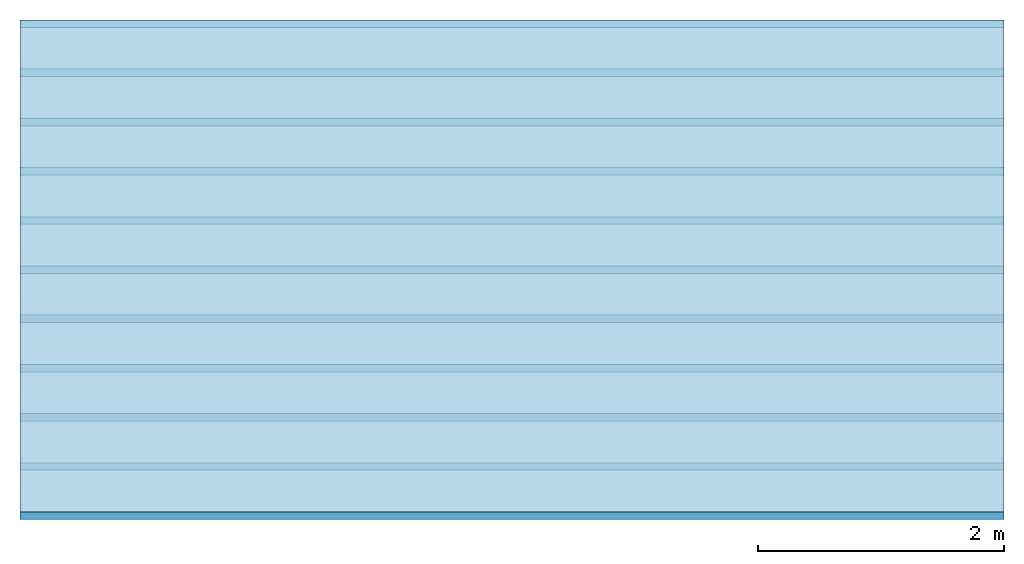
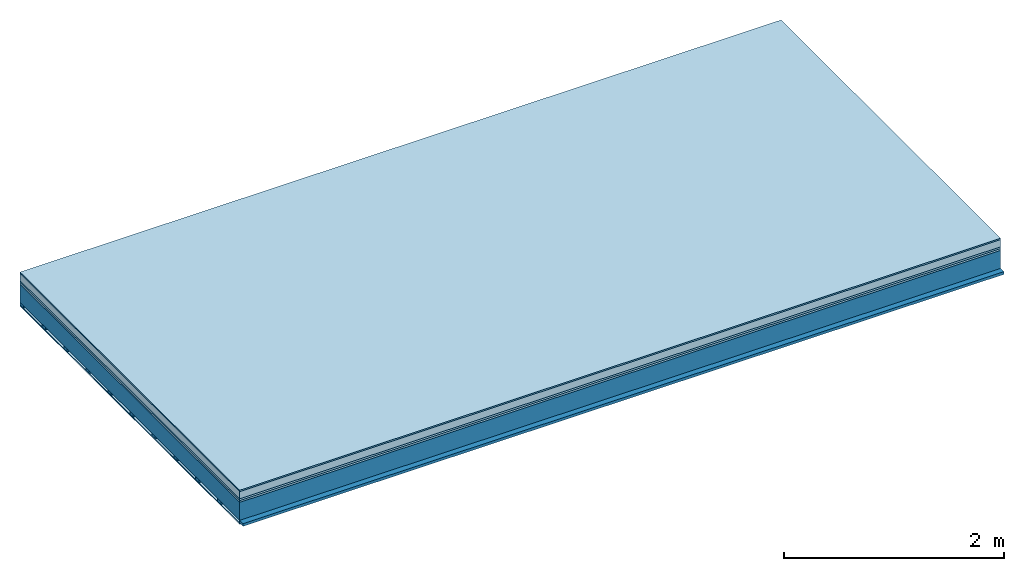
# One storey: 6 plates, 2 members, 1 element without a shape of its own.
"""IFC4 building model written with IfcOpenShell, lengths in metres."""

from ifc_helpers import new_model, si_unit, derived_unit, direction, frame, frame_2d, origin, origin_with_axes, place, context, project, spatial, rectangle, extrude, material, layer, layer_set, type_object, element, aggregate, save


model = new_model("IFC4")

# Units and contexts
plan_context = context("Plan", 3, precision=1e-05, world=origin(), true_north=direction((0.0, 1.0)))
model_context = context("Model", 3, precision=1e-05, world=origin(), true_north=direction((0.0, 1.0)))
ifc_project = project(units=[si_unit("LENGTHUNIT", "METRE"), derived_unit("SOUNDPRESSUREUNIT", [(si_unit("PRESSUREUNIT", "PASCAL", prefix="MICRO"), 0)]), si_unit("ENERGYUNIT", "JOULE", prefix="MEGA"), si_unit("MASSUNIT", "GRAM", prefix="KILO"), derived_unit("THERMALTRANSMITTANCEUNIT", [(si_unit("POWERUNIT", "WATT"), 1), (si_unit("AREAUNIT", "SQUARE_METRE"), -1), (si_unit("THERMODYNAMICTEMPERATUREUNIT", "KELVIN"), -1)]), derived_unit("AREADENSITYUNIT", [(si_unit("MASSUNIT", "GRAM", prefix="KILO"), 1), (si_unit("AREAUNIT", "SQUARE_METRE"), -1)]), derived_unit("USERDEFINED", [(si_unit("ENERGYUNIT", "JOULE", prefix="MEGA"), 1), (si_unit("AREAUNIT", "SQUARE_METRE"), -1)])], contexts=[plan_context, model_context])

# Site, building, storey
site = spatial("IfcSite", under=ifc_project)
building_placement = place(None, origin())
building = spatial("IfcBuilding", under=site, at=building_placement)
storey_placement = place(building_placement, origin())
storey = spatial("IfcBuildingStorey", under=building, at=storey_placement)

# Slab, members, plates
ifc_material_1 = material(Category="11.013")
ifc_layer_1 = layer(ifc_material_1, 0.015, Name="Flooring")
ifc_material_2 = material(Name="Cement screed", Category="04.006")
ifc_layer_2 = layer(ifc_material_2, 0.08, Name="On-material")
ifc_material_3 = material(Name="Wood fiber generic product", Category="10.009")
ifc_layer_3 = layer(ifc_material_3, 0.02, Name="Impact sound insulation")
ifc_material_4 = material(Category="10.004")
ifc_layer_4 = layer(ifc_material_4, 0.02, Name="Additional insulation")
ifc_material_5 = material(Name="no composite action")
ifc_layer_5 = layer(ifc_material_5, 0.0, Name="Bond")
ifc_layer_6 = layer(None, 0.2, Name="Supporting structure")
ifc_material_6 = material(Name="of the art")
ifc_layer_7 = layer(ifc_material_6, 0.0, Name="Bond")
ifc_layer_8 = layer(None, 0.03, Name="Battens / profiles")
ifc_material_7 = material(Name="Plasterboard type A", Category="03.008")
ifc_layer_9 = layer(ifc_material_7, 0.0125, Name="Ceiling covering 1st layer")
ifc_material_8 = material(Category="04.001")
ifc_layer_10 = layer(ifc_material_8, 0.003, Name="Surface / treatment")
ifc_layer_set = layer_set([ifc_layer_1, ifc_layer_2, ifc_layer_3, ifc_layer_4, ifc_layer_5, ifc_layer_6, ifc_layer_7, ifc_layer_8, ifc_layer_9, ifc_layer_10])
slab_type = type_object("IfcSlabType", Name="A2145", PredefinedType="NOTDEFINED", material=ifc_layer_set)
slab_placement = place(None, frame((0.0, 0.0, 0.0), z_axis=(0.0, 0.0, -1.0), x_axis=(1.0, 0.0, 0.0)))
slab = element("IfcSlab", 1, at=slab_placement, inside=storey, type_object=slab_type, material=ifc_layer_set, Name="Slab #1")
ifc_material_9 = material(Name="Solid timber panel")
member_1_placement = place(slab_placement, origin())
member_1 = element("IfcMember", 2, at=member_1_placement, material=ifc_material_9, Name="Supporting structure", context=plan_context, shape_type="SweptSolid", body=[
    extrude(rectangle(XDim=1.0, YDim=0.2, at=frame_2d((0.5, 0.1), x_axis=(1.0, 0.0))), frame((0.0, 4.0, 0.135), z_axis=(0.0, -1.0, 0.0), x_axis=(1.0, 0.0, 0.0)), (0.0, 0.0, 1.0), 4.0),
    extrude(rectangle(XDim=1.0, YDim=0.2, at=frame_2d((0.5, 0.1), x_axis=(1.0, 0.0))), frame((1.0, 4.0, 0.135), z_axis=(0.0, -1.0, 0.0), x_axis=(1.0, 0.0, 0.0)), (0.0, 0.0, 1.0), 4.0),
    extrude(rectangle(XDim=1.0, YDim=0.2, at=frame_2d((0.5, 0.1), x_axis=(1.0, 0.0))), frame((2.0, 4.0, 0.135), z_axis=(0.0, -1.0, 0.0), x_axis=(1.0, 0.0, 0.0)), (0.0, 0.0, 1.0), 4.0),
    extrude(rectangle(XDim=1.0, YDim=0.2, at=frame_2d((0.5, 0.1), x_axis=(1.0, 0.0))), frame((3.0, 4.0, 0.135), z_axis=(0.0, -1.0, 0.0), x_axis=(1.0, 0.0, 0.0)), (0.0, 0.0, 1.0), 4.0),
    extrude(rectangle(XDim=1.0, YDim=0.2, at=frame_2d((0.5, 0.1), x_axis=(1.0, 0.0))), frame((4.0, 4.0, 0.135), z_axis=(0.0, -1.0, 0.0), x_axis=(1.0, 0.0, 0.0)), (0.0, 0.0, 1.0), 4.0),
    extrude(rectangle(XDim=1.0, YDim=0.2, at=frame_2d((0.5, 0.1), x_axis=(1.0, 0.0))), frame((5.0, 4.0, 0.135), z_axis=(0.0, -1.0, 0.0), x_axis=(1.0, 0.0, 0.0)), (0.0, 0.0, 1.0), 4.0),
    extrude(rectangle(XDim=1.0, YDim=0.2, at=frame_2d((0.5, 0.1), x_axis=(1.0, 0.0))), frame((6.0, 4.0, 0.135), z_axis=(0.0, -1.0, 0.0), x_axis=(1.0, 0.0, 0.0)), (0.0, 0.0, 1.0), 4.0),
    extrude(rectangle(XDim=1.0, YDim=0.2, at=frame_2d((0.5, 0.1), x_axis=(1.0, 0.0))), frame((7.0, 4.0, 0.135), z_axis=(0.0, -1.0, 0.0), x_axis=(1.0, 0.0, 0.0)), (0.0, 0.0, 1.0), 4.0),
])
ifc_material_10 = material()
member_2_placement = place(slab_placement, origin())
member_2 = element("IfcMember", 3, at=member_2_placement, material=ifc_material_10, Name="Battens / profiles", context=plan_context, shape_type="SweptSolid", body=[
    extrude(rectangle(XDim=0.06, YDim=0.03, at=frame_2d((0.03, 0.015), x_axis=(1.0, 0.0))), frame((0.0, 0.0, 0.335), z_axis=(1.0, 0.0, 0.0), x_axis=(0.0, 1.0, 0.0)), (0.0, 0.0, 1.0), 8.0),
    extrude(rectangle(XDim=0.06, YDim=0.03, at=frame_2d((0.03, 0.015), x_axis=(1.0, 0.0))), frame((0.0, 0.4, 0.335), z_axis=(1.0, 0.0, 0.0), x_axis=(0.0, 1.0, 0.0)), (0.0, 0.0, 1.0), 8.0),
    extrude(rectangle(XDim=0.06, YDim=0.03, at=frame_2d((0.03, 0.015), x_axis=(1.0, 0.0))), frame((0.0, 0.8, 0.335), z_axis=(1.0, 0.0, 0.0), x_axis=(0.0, 1.0, 0.0)), (0.0, 0.0, 1.0), 8.0),
    extrude(rectangle(XDim=0.06, YDim=0.03, at=frame_2d((0.03, 0.015), x_axis=(1.0, 0.0))), frame((0.0, 1.2, 0.335), z_axis=(1.0, 0.0, 0.0), x_axis=(0.0, 1.0, 0.0)), (0.0, 0.0, 1.0), 8.0),
    extrude(rectangle(XDim=0.06, YDim=0.03, at=frame_2d((0.03, 0.015), x_axis=(1.0, 0.0))), frame((0.0, 1.6, 0.335), z_axis=(1.0, 0.0, 0.0), x_axis=(0.0, 1.0, 0.0)), (0.0, 0.0, 1.0), 8.0),
    extrude(rectangle(XDim=0.06, YDim=0.03, at=frame_2d((0.03, 0.015), x_axis=(1.0, 0.0))), frame((0.0, 2.0, 0.335), z_axis=(1.0, 0.0, 0.0), x_axis=(0.0, 1.0, 0.0)), (0.0, 0.0, 1.0), 8.0),
    extrude(rectangle(XDim=0.06, YDim=0.03, at=frame_2d((0.03, 0.015), x_axis=(1.0, 0.0))), frame((0.0, 2.4, 0.335), z_axis=(1.0, 0.0, 0.0), x_axis=(0.0, 1.0, 0.0)), (0.0, 0.0, 1.0), 8.0),
    extrude(rectangle(XDim=0.06, YDim=0.03, at=frame_2d((0.03, 0.015), x_axis=(1.0, 0.0))), frame((0.0, 2.8, 0.335), z_axis=(1.0, 0.0, 0.0), x_axis=(0.0, 1.0, 0.0)), (0.0, 0.0, 1.0), 8.0),
    extrude(rectangle(XDim=0.06, YDim=0.03, at=frame_2d((0.03, 0.015), x_axis=(1.0, 0.0))), frame((0.0, 3.2, 0.335), z_axis=(1.0, 0.0, 0.0), x_axis=(0.0, 1.0, 0.0)), (0.0, 0.0, 1.0), 8.0),
    extrude(rectangle(XDim=0.06, YDim=0.03, at=frame_2d((0.03, 0.015), x_axis=(1.0, 0.0))), frame((0.0, 3.6, 0.335), z_axis=(1.0, 0.0, 0.0), x_axis=(0.0, 1.0, 0.0)), (0.0, 0.0, 1.0), 8.0),
    extrude(rectangle(XDim=0.06, YDim=0.03, at=frame_2d((0.03, 0.015), x_axis=(1.0, 0.0))), frame((0.0, 4.0, 0.335), z_axis=(1.0, 0.0, 0.0), x_axis=(0.0, 1.0, 0.0)), (0.0, 0.0, 1.0), 8.0),
])
plate_1_placement = place(slab_placement, origin())
plate_1 = element("IfcPlate", 4, at=plate_1_placement, material=ifc_material_1, Name="Flooring", context=plan_context, shape_type="SweptSolid", body=[
    extrude(rectangle(XDim=8.0, YDim=4.0, at=frame_2d((4.0, 2.0), x_axis=(1.0, 0.0))), origin_with_axes(), (0.0, 0.0, 1.0), 0.015),
])
plate_2_placement = place(slab_placement, origin())
plate_2 = element("IfcPlate", 5, at=plate_2_placement, material=ifc_material_2, Name="On-material", context=plan_context, shape_type="SweptSolid", body=[
    extrude(rectangle(XDim=8.0, YDim=4.0, at=frame_2d((4.0, 2.0), x_axis=(1.0, 0.0))), frame((0.0, 0.0, 0.015), z_axis=(0.0, 0.0, 1.0), x_axis=(1.0, 0.0, 0.0)), (0.0, 0.0, 1.0), 0.08),
])
plate_3_placement = place(slab_placement, origin())
plate_3 = element("IfcPlate", 6, at=plate_3_placement, material=ifc_material_3, Name="Impact sound insulation", context=plan_context, shape_type="SweptSolid", body=[
    extrude(rectangle(XDim=8.0, YDim=4.0, at=frame_2d((4.0, 2.0), x_axis=(1.0, 0.0))), frame((0.0, 0.0, 0.095), z_axis=(0.0, 0.0, 1.0), x_axis=(1.0, 0.0, 0.0)), (0.0, 0.0, 1.0), 0.02),
])
plate_4_placement = place(slab_placement, origin())
plate_4 = element("IfcPlate", 7, at=plate_4_placement, material=ifc_material_4, Name="Additional insulation", context=plan_context, shape_type="SweptSolid", body=[
    extrude(rectangle(XDim=8.0, YDim=4.0, at=frame_2d((4.0, 2.0), x_axis=(1.0, 0.0))), frame((0.0, 0.0, 0.115), z_axis=(0.0, 0.0, 1.0), x_axis=(1.0, 0.0, 0.0)), (0.0, 0.0, 1.0), 0.02),
])
plate_5_placement = place(slab_placement, origin())
plate_5 = element("IfcPlate", 8, at=plate_5_placement, material=ifc_material_7, Name="Ceiling covering 1st layer", context=plan_context, shape_type="SweptSolid", body=[
    extrude(rectangle(XDim=8.0, YDim=4.0, at=frame_2d((4.0, 2.0), x_axis=(1.0, 0.0))), frame((0.0, 0.0, 0.365), z_axis=(0.0, 0.0, 1.0), x_axis=(1.0, 0.0, 0.0)), (0.0, 0.0, 1.0), 0.0125),
])
plate_6_placement = place(slab_placement, origin())
plate_6 = element("IfcPlate", 9, at=plate_6_placement, material=ifc_material_8, Name="Surface / treatment", context=plan_context, shape_type="SweptSolid", body=[
    extrude(rectangle(XDim=8.0, YDim=4.0, at=frame_2d((4.0, 2.0), x_axis=(1.0, 0.0))), frame((0.0, 0.0, 0.3775), z_axis=(0.0, 0.0, 1.0), x_axis=(1.0, 0.0, 0.0)), (0.0, 0.0, 1.0), 0.003),
])
aggregate(slab, [plate_1, plate_2, plate_3, plate_4, member_1, member_2, plate_5, plate_6])

save(model, "model.ifc")
